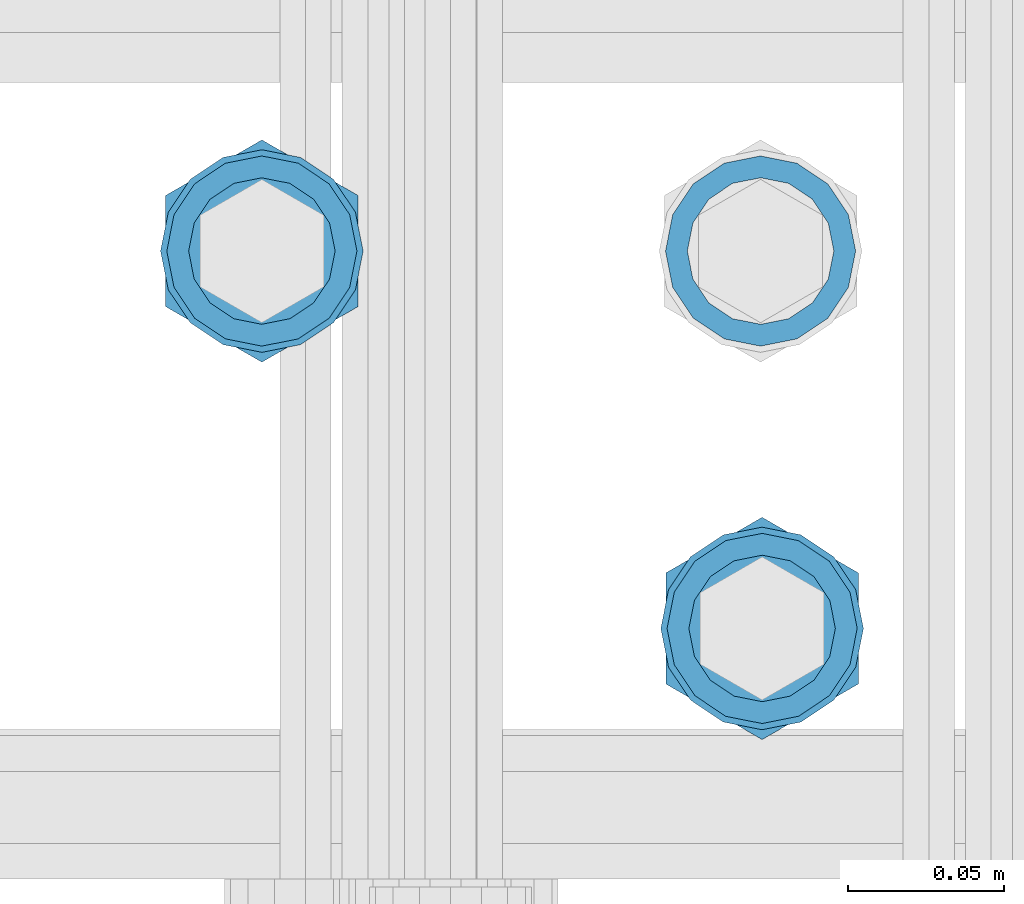
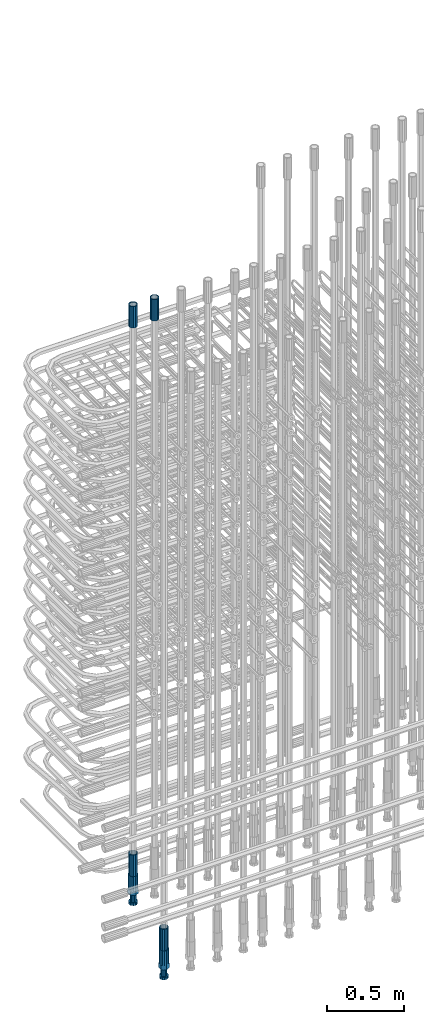
# One storey, part 34 of 177: 6 beams.
"""IFC2X3 building model written with IfcOpenShell, lengths in millimetres."""

from ifc_helpers import new_model, si_unit, frame, origin_with_axes, place, context, subcontext, project, spatial, faceted_brep, material, type_object, element, save


model = new_model("IFC2X3")

# Units and contexts
model_context_1 = context("Model", 3, precision=1e-05, world=origin_with_axes())
model_context_2 = context("Model", 3, precision=1e-05, world=origin_with_axes())
body_context = subcontext(model_context_2, "Body", "Model", "MODEL_VIEW")
ifc_project = project(units=[si_unit("LENGTHUNIT", "METRE", prefix="MILLI"), si_unit("AREAUNIT", "SQUARE_METRE"), si_unit("VOLUMEUNIT", "CUBIC_METRE"), si_unit("MASSUNIT", "GRAM", prefix="KILO"), si_unit("TIMEUNIT", "SECOND"), si_unit("PLANEANGLEUNIT", "RADIAN"), si_unit("SOLIDANGLEUNIT", "STERADIAN"), si_unit("THERMODYNAMICTEMPERATUREUNIT", "DEGREE_CELSIUS"), si_unit("LUMINOUSINTENSITYUNIT", "LUMEN")], contexts=[model_context_1])

# Site, building, storey
site_placement = place(None, origin_with_axes())
site = spatial("IfcSite", under=ifc_project, at=site_placement, CompositionType="ELEMENT")
building_placement = place(site_placement, origin_with_axes())
building = spatial("IfcBuilding", under=site, at=building_placement, Name="Undefined", CompositionType="ELEMENT")
storey_placement = place(building_placement, origin_with_axes())
storey = spatial("IfcBuildingStorey", under=building, at=storey_placement, Name="Undefined", CompositionType="ELEMENT", Elevation=0.0)

# Beams
ifc_material = material(Name="STEEL/S275")
beam_type_1 = type_object("IfcBeamType", PredefinedType="NOTDEFINED")
beam_1_placement = place(storey_placement, frame((2030235.50306268, 6205277.49272666, 23229.9858194793), z_axis=(1.0, 0.0, 0.0), x_axis=(0.0, 0.0, 1.0)))
element("IfcBeam", 1, at=beam_1_placement, inside=storey, type_object=beam_type_1, material=ifc_material, Name="AG40N", context=body_context, shape_type="Brep", body=[
    faceted_brep([(0.0, -23.5000000001164, -9.31322574615479e-10), (0.0, -21.7111690140155, 8.99306066054851), (170.0, -21.7111690140155, 8.99306066054851), (170.0, -23.5, 0.0), (0.0, -16.6170093578839, 16.6170093575493), (170.0, -16.6170093578839, 16.6170093575493), (0.0, -8.99306066057943, 21.7111690137535), (170.0, -8.99306066057943, 21.7111690137535), (0.0, 1.16415321826935e-10, 23.5), (170.0, 0.0, 23.5), (0.0, 8.99306066057943, 21.7111690137535), (170.0, 8.99306066057943, 21.7111690137535), (0.0, 16.6170093578839, 16.6170093575493), (170.0, 16.6170093578839, 16.6170093575493), (0.0, 21.7111690140155, 8.99306066054851), (170.0, 21.7111690140155, 8.99306066054851), (0.0, 23.5000000001164, -9.31322574615479e-10), (170.0, 23.5, 0.0), (0.0, 21.7111690140155, -8.99306066054851), (170.0, 21.7111690140155, -8.99306066054851), (0.0, 16.6170093578839, -16.6170093575493), (170.0, 16.6170093578839, -16.6170093575493), (0.0, 8.99306066057943, -21.7111690137535), (170.0, 8.99306066057943, -21.7111690137535), (0.0, 1.16415321826935e-10, -23.5000000009313), (170.0, 0.0, -23.5), (0.0, -8.99306066057943, -21.7111690137535), (170.0, -8.99306066057943, -21.7111690137535), (0.0, -16.6170093578839, -16.6170093575493), (170.0, -16.6170093578839, -16.6170093575493), (0.0, -21.7111690140155, -8.99306066054851), (170.0, -21.7111690140155, -8.99306066054851), (0.0, -30.5, 0.0), (0.0, -28.1783257415937, -11.6718446873128), (170.0, -28.1783257415937, -11.6718446873128), (170.0, -30.5, 0.0), (0.0, -21.5667568261888, -21.5667568258941), (170.0, -21.5667568261888, -21.5667568258941), (0.0, -11.6718446871346, -28.1783257415518), (170.0, -11.6718446871346, -28.1783257415518), (0.0, 0.0, -30.5), (170.0, 0.0, -30.5), (0.0, 11.6718446871346, -28.1783257415518), (170.0, 11.6718446871346, -28.1783257415518), (0.0, 21.5667568261888, -21.5667568258941), (170.0, 21.5667568261888, -21.5667568258941), (0.0, 28.1783257415937, -11.6718446873128), (170.0, 28.1783257415937, -11.6718446873128), (0.0, 30.5, 0.0), (170.0, 30.5, 0.0), (0.0, 28.1783257415937, 11.6718446873128), (170.0, 28.1783257415937, 11.6718446873128), (0.0, 21.5667568261888, 21.5667568258941), (170.0, 21.5667568261888, 21.5667568258941), (0.0, 11.6718446871346, 28.1783257415518), (170.0, 11.6718446871346, 28.1783257415518), (0.0, 0.0, 30.5), (170.0, 0.0, 30.5), (0.0, -11.6718446871346, 28.1783257415518), (170.0, -11.6718446871346, 28.1783257415518), (0.0, -21.5667568261888, 21.5667568258941), (170.0, -21.5667568261888, 21.5667568258941), (0.0, -28.1783257415937, 11.6718446873128), (170.0, -28.1783257415937, 11.6718446873128)], [[[0, 1, 2, 3]], [[1, 4, 5, 2]], [[4, 6, 7, 5]], [[6, 8, 9, 7]], [[8, 10, 11, 9]], [[10, 12, 13, 11]], [[12, 14, 15, 13]], [[14, 16, 17, 15]], [[16, 18, 19, 17]], [[18, 20, 21, 19]], [[20, 22, 23, 21]], [[22, 24, 25, 23]], [[24, 26, 27, 25]], [[26, 28, 29, 27]], [[28, 30, 31, 29]], [[30, 0, 3, 31]], [[32, 33, 34, 35]], [[33, 36, 37, 34]], [[36, 38, 39, 37]], [[38, 40, 41, 39]], [[40, 42, 43, 41]], [[42, 44, 45, 43]], [[44, 46, 47, 45]], [[46, 48, 49, 47]], [[48, 50, 51, 49]], [[50, 52, 53, 51]], [[52, 54, 55, 53]], [[54, 56, 57, 55]], [[56, 58, 59, 57]], [[58, 60, 61, 59]], [[60, 62, 63, 61]], [[62, 32, 35, 63]], [[37, 39, 41, 43, 45, 47, 49, 51, 53, 55, 57, 59, 61, 63, 35, 34], [5, 7, 9, 11, 13, 15, 17, 19, 21, 23, 25, 27, 29, 31, 3, 2]], [[62, 60, 58, 56, 54, 52, 50, 48, 46, 44, 42, 40, 38, 36, 33, 32], [30, 28, 26, 24, 22, 20, 18, 16, 14, 12, 10, 8, 6, 4, 1, 0]]]),
])
beam_2_placement = place(storey_placement, frame((2030075.5030627, 6205277.49272665, 19060.9668004261), z_axis=(-1.0, 0.0, 0.0), x_axis=(0.0, 0.0, -1.0)))
element("IfcBeam", 2, at=beam_2_placement, inside=storey, type_object=beam_type_1, material=ifc_material, Name="AG40N", context=body_context, shape_type="Brep", body=[
    faceted_brep([(0.0, -23.5000000001164, -9.31322574615479e-10), (0.0, -21.7111690140155, 8.99306066054851), (170.0, -21.7111690140155, 8.99306066054851), (170.0, -23.5, 0.0), (0.0, -16.6170093578839, 16.6170093575493), (170.0, -16.6170093578839, 16.6170093575493), (0.0, -8.99306066057943, 21.7111690137535), (170.0, -8.99306066057943, 21.7111690137535), (0.0, 1.16415321826935e-10, 23.5), (170.0, 0.0, 23.5), (0.0, 8.99306066057943, 21.7111690137535), (170.0, 8.99306066057943, 21.7111690137535), (0.0, 16.6170093578839, 16.6170093575493), (170.0, 16.6170093578839, 16.6170093575493), (0.0, 21.7111690140155, 8.99306066054851), (170.0, 21.7111690140155, 8.99306066054851), (0.0, 23.5000000001164, -9.31322574615479e-10), (170.0, 23.5, 0.0), (0.0, 21.7111690140155, -8.99306066054851), (170.0, 21.7111690140155, -8.99306066054851), (0.0, 16.6170093578839, -16.6170093575493), (170.0, 16.6170093578839, -16.6170093575493), (0.0, 8.99306066057943, -21.7111690137535), (170.0, 8.99306066057943, -21.7111690137535), (0.0, 1.16415321826935e-10, -23.5000000009313), (170.0, 0.0, -23.5), (0.0, -8.99306066057943, -21.7111690137535), (170.0, -8.99306066057943, -21.7111690137535), (0.0, -16.6170093578839, -16.6170093575493), (170.0, -16.6170093578839, -16.6170093575493), (0.0, -21.7111690140155, -8.99306066054851), (170.0, -21.7111690140155, -8.99306066054851), (0.0, -30.5, 0.0), (0.0, -28.1783257415937, -11.6718446873128), (170.0, -28.1783257415937, -11.6718446873128), (170.0, -30.5, 0.0), (0.0, -21.5667568261888, -21.5667568258941), (170.0, -21.5667568261888, -21.5667568258941), (0.0, -11.6718446871346, -28.1783257415518), (170.0, -11.6718446871346, -28.1783257415518), (0.0, 0.0, -30.5), (170.0, 0.0, -30.5), (0.0, 11.6718446871346, -28.1783257415518), (170.0, 11.6718446871346, -28.1783257415518), (0.0, 21.5667568261888, -21.5667568258941), (170.0, 21.5667568261888, -21.5667568258941), (0.0, 28.1783257415937, -11.6718446873128), (170.0, 28.1783257415937, -11.6718446873128), (0.0, 30.5, 0.0), (170.0, 30.5, 0.0), (0.0, 28.1783257415937, 11.6718446873128), (170.0, 28.1783257415937, 11.6718446873128), (0.0, 21.5667568261888, 21.5667568258941), (170.0, 21.5667568261888, 21.5667568258941), (0.0, 11.6718446871346, 28.1783257415518), (170.0, 11.6718446871346, 28.1783257415518), (0.0, 0.0, 30.5), (170.0, 0.0, 30.5), (0.0, -11.6718446871346, 28.1783257415518), (170.0, -11.6718446871346, 28.1783257415518), (0.0, -21.5667568261888, 21.5667568258941), (170.0, -21.5667568261888, 21.5667568258941), (0.0, -28.1783257415937, 11.6718446873128), (170.0, -28.1783257415937, 11.6718446873128)], [[[0, 1, 2, 3]], [[1, 4, 5, 2]], [[4, 6, 7, 5]], [[6, 8, 9, 7]], [[8, 10, 11, 9]], [[10, 12, 13, 11]], [[12, 14, 15, 13]], [[14, 16, 17, 15]], [[16, 18, 19, 17]], [[18, 20, 21, 19]], [[20, 22, 23, 21]], [[22, 24, 25, 23]], [[24, 26, 27, 25]], [[26, 28, 29, 27]], [[28, 30, 31, 29]], [[30, 0, 3, 31]], [[32, 33, 34, 35]], [[33, 36, 37, 34]], [[36, 38, 39, 37]], [[38, 40, 41, 39]], [[40, 42, 43, 41]], [[42, 44, 45, 43]], [[44, 46, 47, 45]], [[46, 48, 49, 47]], [[48, 50, 51, 49]], [[50, 52, 53, 51]], [[52, 54, 55, 53]], [[54, 56, 57, 55]], [[56, 58, 59, 57]], [[58, 60, 61, 59]], [[60, 62, 63, 61]], [[62, 32, 35, 63]], [[37, 39, 41, 43, 45, 47, 49, 51, 53, 55, 57, 59, 61, 63, 35, 34], [5, 7, 9, 11, 13, 15, 17, 19, 21, 23, 25, 27, 29, 31, 3, 2]], [[62, 60, 58, 56, 54, 52, 50, 48, 46, 44, 42, 40, 38, 36, 33, 32], [30, 28, 26, 24, 22, 20, 18, 16, 14, 12, 10, 8, 6, 4, 1, 0]]]),
])
beam_3_placement = place(storey_placement, frame((2030075.50306268, 6205277.49272666, 23229.9858194793), z_axis=(1.0, 0.0, 0.0), x_axis=(0.0, 0.0, 1.0)))
element("IfcBeam", 3, at=beam_3_placement, inside=storey, type_object=beam_type_1, material=ifc_material, Name="AG40N", context=body_context, shape_type="Brep", body=[
    faceted_brep([(0.0, -23.5000000001164, -9.31322574615479e-10), (0.0, -21.7111690140155, 8.99306066054851), (170.0, -21.7111690140155, 8.99306066054851), (170.0, -23.5, 0.0), (0.0, -16.6170093578839, 16.6170093575493), (170.0, -16.6170093578839, 16.6170093575493), (0.0, -8.99306066057943, 21.7111690137535), (170.0, -8.99306066057943, 21.7111690137535), (0.0, 1.16415321826935e-10, 23.5), (170.0, 0.0, 23.5), (0.0, 8.99306066057943, 21.7111690137535), (170.0, 8.99306066057943, 21.7111690137535), (0.0, 16.6170093578839, 16.6170093575493), (170.0, 16.6170093578839, 16.6170093575493), (0.0, 21.7111690140155, 8.99306066054851), (170.0, 21.7111690140155, 8.99306066054851), (0.0, 23.5000000001164, -9.31322574615479e-10), (170.0, 23.5, 0.0), (0.0, 21.7111690140155, -8.99306066054851), (170.0, 21.7111690140155, -8.99306066054851), (0.0, 16.6170093578839, -16.6170093575493), (170.0, 16.6170093578839, -16.6170093575493), (0.0, 8.99306066057943, -21.7111690137535), (170.0, 8.99306066057943, -21.7111690137535), (0.0, 1.16415321826935e-10, -23.5000000009313), (170.0, 0.0, -23.5), (0.0, -8.99306066057943, -21.7111690137535), (170.0, -8.99306066057943, -21.7111690137535), (0.0, -16.6170093578839, -16.6170093575493), (170.0, -16.6170093578839, -16.6170093575493), (0.0, -21.7111690140155, -8.99306066054851), (170.0, -21.7111690140155, -8.99306066054851), (0.0, -30.5, 0.0), (0.0, -28.1783257415937, -11.6718446873128), (170.0, -28.1783257415937, -11.6718446873128), (170.0, -30.5, 0.0), (0.0, -21.5667568261888, -21.5667568258941), (170.0, -21.5667568261888, -21.5667568258941), (0.0, -11.6718446871346, -28.1783257415518), (170.0, -11.6718446871346, -28.1783257415518), (0.0, 0.0, -30.5), (170.0, 0.0, -30.5), (0.0, 11.6718446871346, -28.1783257415518), (170.0, 11.6718446871346, -28.1783257415518), (0.0, 21.5667568261888, -21.5667568258941), (170.0, 21.5667568261888, -21.5667568258941), (0.0, 28.1783257415937, -11.6718446873128), (170.0, 28.1783257415937, -11.6718446873128), (0.0, 30.5, 0.0), (170.0, 30.5, 0.0), (0.0, 28.1783257415937, 11.6718446873128), (170.0, 28.1783257415937, 11.6718446873128), (0.0, 21.5667568261888, 21.5667568258941), (170.0, 21.5667568261888, 21.5667568258941), (0.0, 11.6718446871346, 28.1783257415518), (170.0, 11.6718446871346, 28.1783257415518), (0.0, 0.0, 30.5), (170.0, 0.0, 30.5), (0.0, -11.6718446871346, 28.1783257415518), (170.0, -11.6718446871346, 28.1783257415518), (0.0, -21.5667568261888, 21.5667568258941), (170.0, -21.5667568261888, 21.5667568258941), (0.0, -28.1783257415937, 11.6718446873128), (170.0, -28.1783257415937, 11.6718446873128)], [[[0, 1, 2, 3]], [[1, 4, 5, 2]], [[4, 6, 7, 5]], [[6, 8, 9, 7]], [[8, 10, 11, 9]], [[10, 12, 13, 11]], [[12, 14, 15, 13]], [[14, 16, 17, 15]], [[16, 18, 19, 17]], [[18, 20, 21, 19]], [[20, 22, 23, 21]], [[22, 24, 25, 23]], [[24, 26, 27, 25]], [[26, 28, 29, 27]], [[28, 30, 31, 29]], [[30, 0, 3, 31]], [[32, 33, 34, 35]], [[33, 36, 37, 34]], [[36, 38, 39, 37]], [[38, 40, 41, 39]], [[40, 42, 43, 41]], [[42, 44, 45, 43]], [[44, 46, 47, 45]], [[46, 48, 49, 47]], [[48, 50, 51, 49]], [[50, 52, 53, 51]], [[52, 54, 55, 53]], [[54, 56, 57, 55]], [[56, 58, 59, 57]], [[58, 60, 61, 59]], [[60, 62, 63, 61]], [[62, 32, 35, 63]], [[37, 39, 41, 43, 45, 47, 49, 51, 53, 55, 57, 59, 61, 63, 35, 34], [5, 7, 9, 11, 13, 15, 17, 19, 21, 23, 25, 27, 29, 31, 3, 2]], [[62, 60, 58, 56, 54, 52, 50, 48, 46, 44, 42, 40, 38, 36, 33, 32], [30, 28, 26, 24, 22, 20, 18, 16, 14, 12, 10, 8, 6, 4, 1, 0]]]),
])
beam_4_placement = place(storey_placement, frame((2030236.00256268, 6205156.4084753, 18490.9668004282), z_axis=(-1.0, 0.0, 0.0), x_axis=(0.0, 0.0, -1.0)))
element("IfcBeam", 4, at=beam_4_placement, inside=storey, type_object=beam_type_1, material=ifc_material, Name="AG40N", context=body_context, shape_type="Brep", body=[
    faceted_brep([(0.0, -23.5000000001164, -9.31322574615479e-10), (0.0, -21.7111690140155, 8.99306066054851), (170.0, -21.7111690140155, 8.99306066054851), (170.0, -23.5, 0.0), (0.0, -16.6170093578839, 16.6170093575493), (170.0, -16.6170093578839, 16.6170093575493), (0.0, -8.99306066057943, 21.7111690137535), (170.0, -8.99306066057943, 21.7111690137535), (0.0, 1.16415321826935e-10, 23.5), (170.0, 0.0, 23.5), (0.0, 8.99306066057943, 21.7111690137535), (170.0, 8.99306066057943, 21.7111690137535), (0.0, 16.6170093578839, 16.6170093575493), (170.0, 16.6170093578839, 16.6170093575493), (0.0, 21.7111690140155, 8.99306066054851), (170.0, 21.7111690140155, 8.99306066054851), (0.0, 23.5000000001164, -9.31322574615479e-10), (170.0, 23.5, 0.0), (0.0, 21.7111690140155, -8.99306066054851), (170.0, 21.7111690140155, -8.99306066054851), (0.0, 16.6170093578839, -16.6170093575493), (170.0, 16.6170093578839, -16.6170093575493), (0.0, 8.99306066057943, -21.7111690137535), (170.0, 8.99306066057943, -21.7111690137535), (0.0, 1.16415321826935e-10, -23.5000000009313), (170.0, 0.0, -23.5), (0.0, -8.99306066057943, -21.7111690137535), (170.0, -8.99306066057943, -21.7111690137535), (0.0, -16.6170093578839, -16.6170093575493), (170.0, -16.6170093578839, -16.6170093575493), (0.0, -21.7111690140155, -8.99306066054851), (170.0, -21.7111690140155, -8.99306066054851), (0.0, -30.5, 0.0), (0.0, -28.1783257415937, -11.6718446873128), (170.0, -28.1783257415937, -11.6718446873128), (170.0, -30.5, 0.0), (0.0, -21.5667568261888, -21.5667568258941), (170.0, -21.5667568261888, -21.5667568258941), (0.0, -11.6718446871346, -28.1783257415518), (170.0, -11.6718446871346, -28.1783257415518), (0.0, 0.0, -30.5), (170.0, 0.0, -30.5), (0.0, 11.6718446871346, -28.1783257415518), (170.0, 11.6718446871346, -28.1783257415518), (0.0, 21.5667568261888, -21.5667568258941), (170.0, 21.5667568261888, -21.5667568258941), (0.0, 28.1783257415937, -11.6718446873128), (170.0, 28.1783257415937, -11.6718446873128), (0.0, 30.5, 0.0), (170.0, 30.5, 0.0), (0.0, 28.1783257415937, 11.6718446873128), (170.0, 28.1783257415937, 11.6718446873128), (0.0, 21.5667568261888, 21.5667568258941), (170.0, 21.5667568261888, 21.5667568258941), (0.0, 11.6718446871346, 28.1783257415518), (170.0, 11.6718446871346, 28.1783257415518), (0.0, 0.0, 30.5), (170.0, 0.0, 30.5), (0.0, -11.6718446871346, 28.1783257415518), (170.0, -11.6718446871346, 28.1783257415518), (0.0, -21.5667568261888, 21.5667568258941), (170.0, -21.5667568261888, 21.5667568258941), (0.0, -28.1783257415937, 11.6718446873128), (170.0, -28.1783257415937, 11.6718446873128)], [[[0, 1, 2, 3]], [[1, 4, 5, 2]], [[4, 6, 7, 5]], [[6, 8, 9, 7]], [[8, 10, 11, 9]], [[10, 12, 13, 11]], [[12, 14, 15, 13]], [[14, 16, 17, 15]], [[16, 18, 19, 17]], [[18, 20, 21, 19]], [[20, 22, 23, 21]], [[22, 24, 25, 23]], [[24, 26, 27, 25]], [[26, 28, 29, 27]], [[28, 30, 31, 29]], [[30, 0, 3, 31]], [[32, 33, 34, 35]], [[33, 36, 37, 34]], [[36, 38, 39, 37]], [[38, 40, 41, 39]], [[40, 42, 43, 41]], [[42, 44, 45, 43]], [[44, 46, 47, 45]], [[46, 48, 49, 47]], [[48, 50, 51, 49]], [[50, 52, 53, 51]], [[52, 54, 55, 53]], [[54, 56, 57, 55]], [[56, 58, 59, 57]], [[58, 60, 61, 59]], [[60, 62, 63, 61]], [[62, 32, 35, 63]], [[37, 39, 41, 43, 45, 47, 49, 51, 53, 55, 57, 59, 61, 63, 35, 34], [5, 7, 9, 11, 13, 15, 17, 19, 21, 23, 25, 27, 29, 31, 3, 2]], [[62, 60, 58, 56, 54, 52, 50, 48, 46, 44, 42, 40, 38, 36, 33, 32], [30, 28, 26, 24, 22, 20, 18, 16, 14, 12, 10, 8, 6, 4, 1, 0]]]),
])
beam_type_2 = type_object("IfcBeamType", Name="ROD65", PredefinedType="NOTDEFINED")
beam_5_placement = place(storey_placement, frame((2030075.50306269, 6205277.49272665, 18890.9668004261), z_axis=(-1.0, 0.0, 0.0), x_axis=(0.0, 0.0, -1.0)))
element("IfcBeam", 5, at=beam_5_placement, inside=storey, type_object=beam_type_2, material=ifc_material, Name="AGB40", ObjectType="ROD65", context=body_context, shape_type="Brep", body=[
    faceted_brep([(117.0, 8.17543110251427, 30.873805644922), (117.0, 17.8250000001863, 30.873805644922), (117.0, 22.0056958701462, 23.6326279877685), (117.0, 12.4372115517035, 30.0260848065373), (117.0, -17.8250000001863, 30.873805644922), (150.200000000186, -17.8250000001863, 30.873805644922), (150.200000000186, 17.8250000001863, 30.873805644922), (117.0, -8.17543110251427, 30.873805644922), (117.0, -12.4372115517035, 30.0260848065373), (117.0, -22.0056958701462, 23.6326279877685), (117.0, -35.6500000003725, 0.0), (150.200000000186, -35.6500000003725, 0.0), (117.0, -30.8443150008097, 8.32369058486074), (117.0, -32.5, 0.0), (117.0, -30.8443150008097, -8.32369058462791), (117.0, -17.8250000001863, -30.873805644922), (150.200000000186, -17.8250000001863, -30.873805644922), (117.0, -22.0056958701462, -23.6326279877685), (117.0, -12.4372115517035, -30.0260848065373), (117.0, -8.17543110251427, -30.873805644922), (117.0, 17.8250000001863, -30.873805644922), (150.200000000186, 17.8250000001863, -30.873805644922), (117.0, 8.17543110251427, -30.873805644922), (117.0, 22.0056958701462, -23.6326279877685), (117.0, 12.4372115517035, -30.0260848065373), (117.0, 35.6500000003725, 0.0), (150.200000000186, 35.6500000003725, 0.0), (117.0, 30.8443150008097, -8.32369058486074), (117.0, 30.8443150008097, 8.32369058462791), (117.0, 32.5, 0.0), (0.0, -22.9809703892097, 22.9809703885621), (0.0, -30.0260848058388, 12.4372115518636), (117.0, -30.0260848067701, 12.4372115519363), (117.0, -22.9809703882784, 22.9809703885112), (-2.3283064365387e-10, 22.9809703892097, -22.9809703885639), (-4.65661287307739e-10, 30.0260848077014, -12.4372115518672), (117.0, 30.0260848067701, -12.4372115519363), (117.0, 22.9809703882784, -22.9809703885112), (-2.3283064365387e-10, -30.0260848067701, -12.4372115518672), (-2.3283064365387e-10, -22.9809703892097, -22.9809703885621), (117.0, -22.9809703882784, -22.9809703885112), (117.0, -30.0260848067701, -12.4372115519363), (-2.3283064365387e-10, -12.4372115507722, 30.0260848066137), (-2.3283064365387e-10, 9.31322574615479e-10, 32.4999999999982), (-2.3283064365387e-10, 12.4372115526348, 30.0260848066137), (0.0, 22.9809703892097, 22.9809703885621), (-2.3283064365387e-10, 30.0260848077014, 12.4372115518636), (-2.3283064365387e-10, 32.5, 0.0), (-2.3283064365387e-10, 12.4372115526348, -30.0260848066173), (-2.3283064365387e-10, 9.31322574615479e-10, -32.5), (-2.3283064365387e-10, -12.4372115517035, -30.0260848066173), (-4.65661287307739e-10, -32.4999999990687, -1.81898940354586e-12), (117.0, 22.9809703882784, 22.9809703885112), (117.0, 30.0260848067701, 12.4372115519363), (117.0, 0.0, -32.5), (117.0, 0.0, 32.5), (150.200000000186, 10.5, -18.1865334794857), (150.200000000186, 0.0, -21.0), (150.200000000186, -10.5, -18.1865334794857), (150.200000000186, -18.18653347902, -10.5), (150.200000000186, -21.0, 0.0), (150.200000000186, -18.18653347902, 10.5), (150.200000000186, -10.5, 18.1865334794857), (150.200000000186, 0.0, 21.0), (150.200000000186, 10.5, 18.1865334794857), (150.200000000186, 18.18653347902, 10.5), (150.200000000186, 21.0, 0.0), (150.200000000186, 18.18653347902, -10.5), (210.980000000447, -10.5, -18.1865334794857), (210.980000000447, 0.0, -21.0), (210.980000000447, -18.18653347902, -10.5), (210.980000000447, -21.0, 0.0), (210.980000000447, -18.18653347902, 10.5), (210.980000000447, -10.5, 18.1865334794857), (210.980000000447, 0.0, 21.0), (210.980000000447, 10.5, 18.1865334794857), (210.980000000447, 18.18653347902, 10.5), (210.980000000447, 21.0, 0.0), (210.980000000447, 18.18653347902, -10.5), (210.980000000447, 10.5, -18.1865334794857), (211.001368442696, -27.7269937992096, -11.491116326768), (211.003082550167, -21.2238094303757, -21.223815418547), (231.002518367059, -21.2131944671273, -21.2132004550658), (231.000804259587, -27.7163788359612, -11.4805013632867), (211.001368440451, -11.4911085031927, -27.7269970395137), (231.000804257343, -11.4804935399443, -27.7163820760325), (210.996487071217, -0.0106065049767494, -30.0106107392348), (230.995922888109, 8.45827162265778e-06, -29.9999957757536), (210.989181586672, 11.46989420522, -27.7269970329944), (230.988617403564, 11.4805091684684, -27.7163820695132), (210.980564180623, 21.2025914648548, -21.2238154064398), (230.979999997515, 21.2132064281031, -21.2132004429586), (210.971946775022, 27.7057703435421, -11.4911163107026), (230.971382591913, 27.7163853067905, -11.4805013472214), (210.96464129175, 29.9893808094785, -0.0106149562634528), (230.964077108642, 29.9999957727268, 7.21774995326996e-09), (210.959759924415, 27.7057638689876, 11.4698863970116), (230.959195741307, 27.7163788322359, 11.4805013604928), (210.958045816944, 21.2025795001537, 21.2025854887906), (230.957481633835, 21.213194463402, 21.2132004522718), (210.95975992666, 11.4698785729706, 27.7057671097573), (230.959195743551, 11.480493536219, 27.7163820732385), (210.964641295894, -0.010623425245285, 29.9893808094785), (230.964077112785, -8.46199691295624e-06, 29.9999957729597), (210.971946780439, -11.4911241354421, 27.705767103238), (230.97138259733, -11.4805091721937, 27.7163820667192), (210.980564186488, -21.2238213950768, 21.2025854766835), (230.980000003379, -21.2132064318284, 21.2132004401647), (210.989181592089, -27.7270002737641, 11.4698863809463), (230.988617408981, -27.7163853105158, 11.4805013444275), (210.996487075361, -30.0106107397005, -0.0106149734929204), (230.995922892253, -29.9999957764521, -1.00117176771164e-08)], [[[0, 1, 2, 3]], [[4, 5, 6, 1, 0, 7]], [[4, 7, 8, 9]], [[10, 11, 5, 4, 9, 12]], [[10, 12, 13, 14]], [[15, 16, 11, 10, 14, 17]], [[15, 17, 18, 19]], [[20, 21, 16, 15, 19, 22]], [[23, 20, 22, 24]], [[25, 26, 21, 20, 23, 27]], [[28, 25, 27, 29]], [[30, 31, 32, 33]], [[34, 35, 36, 37]], [[38, 39, 40, 41]], [[31, 30, 42, 43, 44, 45, 46, 47, 35, 34, 48, 49, 50, 39, 38, 51]], [[46, 45, 52, 53]], [[29, 47, 46, 53, 28]], [[27, 36, 35, 47, 29]], [[23, 37, 36, 27]], [[24, 48, 34, 37, 23]], [[22, 54, 49, 48, 24]], [[19, 54, 22]], [[18, 50, 49, 54, 19]], [[17, 40, 39, 50, 18]], [[14, 41, 40, 17]], [[13, 51, 38, 41, 14]], [[12, 32, 31, 51, 13]], [[9, 33, 32, 12]], [[8, 42, 30, 33, 9]], [[7, 55, 43, 42, 8]], [[0, 55, 7]], [[3, 44, 43, 55, 0]], [[2, 52, 45, 44, 3]], [[28, 53, 52, 2]], [[1, 6, 26, 25, 28, 2]], [[5, 11, 16, 21, 26, 6], [56, 57, 58, 59, 60, 61, 62, 63, 64, 65, 66, 67]], [[68, 58, 57, 69]], [[70, 59, 58, 68]], [[71, 60, 59, 70]], [[72, 61, 60, 71]], [[73, 62, 61, 72]], [[74, 63, 62, 73]], [[75, 64, 63, 74]], [[76, 65, 64, 75]], [[77, 66, 65, 76]], [[78, 67, 66, 77]], [[79, 56, 67, 78]], [[69, 57, 56, 79]], [[80, 81, 82, 83]], [[81, 84, 85, 82]], [[84, 86, 87, 85]], [[86, 88, 89, 87]], [[88, 90, 91, 89]], [[90, 92, 93, 91]], [[92, 94, 95, 93]], [[94, 96, 97, 95]], [[96, 98, 99, 97]], [[98, 100, 101, 99]], [[100, 102, 103, 101]], [[102, 104, 105, 103]], [[104, 106, 107, 105]], [[106, 108, 109, 107]], [[108, 110, 111, 109]], [[82, 85, 87, 89, 91, 93, 95, 97, 99, 101, 103, 105, 107, 109, 111, 83]], [[110, 80, 83, 111]], [[108, 106, 104, 102, 100, 98, 96, 94, 92, 90, 88, 86, 84, 81, 80, 110], [78, 77, 76, 75, 74, 73, 72, 71, 70, 68, 69, 79]]]),
])
beam_6_placement = place(storey_placement, frame((2030236.00256267, 6205156.4084753, 18320.9668004282), z_axis=(-1.0, 0.0, 0.0), x_axis=(0.0, 0.0, -1.0)))
element("IfcBeam", 6, at=beam_6_placement, inside=storey, type_object=beam_type_2, material=ifc_material, Name="AGB40", ObjectType="ROD65", context=body_context, shape_type="Brep", body=[
    faceted_brep([(117.0, 8.17543110251427, 30.873805644922), (117.0, 17.8250000001863, 30.873805644922), (117.0, 22.0056958701462, 23.6326279877685), (117.0, 12.4372115517035, 30.0260848065373), (117.0, -17.8250000001863, 30.873805644922), (150.200000000186, -17.8250000001863, 30.873805644922), (150.200000000186, 17.8250000001863, 30.873805644922), (117.0, -8.17543110251427, 30.873805644922), (117.0, -12.4372115517035, 30.0260848065373), (117.0, -22.0056958701462, 23.6326279877685), (117.0, -35.6500000003725, 0.0), (150.200000000186, -35.6500000003725, 0.0), (117.0, -30.8443150008097, 8.32369058486074), (117.0, -32.5, 0.0), (117.0, -30.8443150008097, -8.32369058462791), (117.0, -17.8250000001863, -30.873805644922), (150.200000000186, -17.8250000001863, -30.873805644922), (117.0, -22.0056958701462, -23.6326279877685), (117.0, -12.4372115517035, -30.0260848065373), (117.0, -8.17543110251427, -30.873805644922), (117.0, 17.8250000001863, -30.873805644922), (150.200000000186, 17.8250000001863, -30.873805644922), (117.0, 8.17543110251427, -30.873805644922), (117.0, 22.0056958701462, -23.6326279877685), (117.0, 12.4372115517035, -30.0260848065373), (117.0, 35.6500000003725, 0.0), (150.200000000186, 35.6500000003725, 0.0), (117.0, 30.8443150008097, -8.32369058486074), (117.0, 30.8443150008097, 8.32369058462791), (117.0, 32.5, 0.0), (0.0, -22.9809703892097, 22.9809703885621), (0.0, -30.0260848058388, 12.4372115518636), (117.0, -30.0260848067701, 12.4372115519363), (117.0, -22.9809703882784, 22.9809703885112), (-2.3283064365387e-10, 22.9809703892097, -22.9809703885639), (-4.65661287307739e-10, 30.0260848077014, -12.4372115518672), (117.0, 30.0260848067701, -12.4372115519363), (117.0, 22.9809703882784, -22.9809703885112), (-2.3283064365387e-10, -30.0260848067701, -12.4372115518672), (-2.3283064365387e-10, -22.9809703892097, -22.9809703885621), (117.0, -22.9809703882784, -22.9809703885112), (117.0, -30.0260848067701, -12.4372115519363), (-2.3283064365387e-10, -12.4372115507722, 30.0260848066137), (-2.3283064365387e-10, 9.31322574615479e-10, 32.4999999999982), (-2.3283064365387e-10, 12.4372115526348, 30.0260848066137), (0.0, 22.9809703892097, 22.9809703885621), (-2.3283064365387e-10, 30.0260848077014, 12.4372115518636), (-2.3283064365387e-10, 32.5, 0.0), (-2.3283064365387e-10, 12.4372115526348, -30.0260848066173), (-2.3283064365387e-10, 9.31322574615479e-10, -32.5), (-2.3283064365387e-10, -12.4372115517035, -30.0260848066173), (-4.65661287307739e-10, -32.4999999990687, -1.81898940354586e-12), (117.0, 22.9809703882784, 22.9809703885112), (117.0, 30.0260848067701, 12.4372115519363), (117.0, 0.0, -32.5), (117.0, 0.0, 32.5), (150.200000000186, 10.5, -18.1865334794857), (150.200000000186, 0.0, -21.0), (150.200000000186, -10.5, -18.1865334794857), (150.200000000186, -18.18653347902, -10.5), (150.200000000186, -21.0, 0.0), (150.200000000186, -18.18653347902, 10.5), (150.200000000186, -10.5, 18.1865334794857), (150.200000000186, 0.0, 21.0), (150.200000000186, 10.5, 18.1865334794857), (150.200000000186, 18.18653347902, 10.5), (150.200000000186, 21.0, 0.0), (150.200000000186, 18.18653347902, -10.5), (210.980000000447, -10.5, -18.1865334794857), (210.980000000447, 0.0, -21.0), (210.980000000447, -18.18653347902, -10.5), (210.980000000447, -21.0, 0.0), (210.980000000447, -18.18653347902, 10.5), (210.980000000447, -10.5, 18.1865334794857), (210.980000000447, 0.0, 21.0), (210.980000000447, 10.5, 18.1865334794857), (210.980000000447, 18.18653347902, 10.5), (210.980000000447, 21.0, 0.0), (210.980000000447, 18.18653347902, -10.5), (210.980000000447, 10.5, -18.1865334794857), (211.001368442696, -27.7269937992096, -11.491116326768), (211.003082550167, -21.2238094303757, -21.223815418547), (231.002518367059, -21.2131944671273, -21.2132004550658), (231.000804259587, -27.7163788359612, -11.4805013632867), (211.001368440451, -11.4911085031927, -27.7269970395137), (231.000804257343, -11.4804935399443, -27.7163820760325), (210.996487071217, -0.0106065049767494, -30.0106107392348), (230.995922888109, 8.45827162265778e-06, -29.9999957757536), (210.989181586672, 11.46989420522, -27.7269970329944), (230.988617403564, 11.4805091684684, -27.7163820695132), (210.980564180623, 21.2025914648548, -21.2238154064398), (230.979999997515, 21.2132064281031, -21.2132004429586), (210.971946775022, 27.7057703435421, -11.4911163107026), (230.971382591913, 27.7163853067905, -11.4805013472214), (210.96464129175, 29.9893808094785, -0.0106149562634528), (230.964077108642, 29.9999957727268, 7.21774995326996e-09), (210.959759924415, 27.7057638689876, 11.4698863970116), (230.959195741307, 27.7163788322359, 11.4805013604928), (210.958045816944, 21.2025795001537, 21.2025854887906), (230.957481633835, 21.213194463402, 21.2132004522718), (210.95975992666, 11.4698785729706, 27.7057671097573), (230.959195743551, 11.480493536219, 27.7163820732385), (210.964641295894, -0.010623425245285, 29.9893808094785), (230.964077112785, -8.46199691295624e-06, 29.9999957729597), (210.971946780439, -11.4911241354421, 27.705767103238), (230.97138259733, -11.4805091721937, 27.7163820667192), (210.980564186488, -21.2238213950768, 21.2025854766835), (230.980000003379, -21.2132064318284, 21.2132004401647), (210.989181592089, -27.7270002737641, 11.4698863809463), (230.988617408981, -27.7163853105158, 11.4805013444275), (210.996487075361, -30.0106107397005, -0.0106149734929204), (230.995922892253, -29.9999957764521, -1.00117176771164e-08)], [[[0, 1, 2, 3]], [[4, 5, 6, 1, 0, 7]], [[4, 7, 8, 9]], [[10, 11, 5, 4, 9, 12]], [[10, 12, 13, 14]], [[15, 16, 11, 10, 14, 17]], [[15, 17, 18, 19]], [[20, 21, 16, 15, 19, 22]], [[23, 20, 22, 24]], [[25, 26, 21, 20, 23, 27]], [[28, 25, 27, 29]], [[30, 31, 32, 33]], [[34, 35, 36, 37]], [[38, 39, 40, 41]], [[31, 30, 42, 43, 44, 45, 46, 47, 35, 34, 48, 49, 50, 39, 38, 51]], [[46, 45, 52, 53]], [[29, 47, 46, 53, 28]], [[27, 36, 35, 47, 29]], [[23, 37, 36, 27]], [[24, 48, 34, 37, 23]], [[22, 54, 49, 48, 24]], [[19, 54, 22]], [[18, 50, 49, 54, 19]], [[17, 40, 39, 50, 18]], [[14, 41, 40, 17]], [[13, 51, 38, 41, 14]], [[12, 32, 31, 51, 13]], [[9, 33, 32, 12]], [[8, 42, 30, 33, 9]], [[7, 55, 43, 42, 8]], [[0, 55, 7]], [[3, 44, 43, 55, 0]], [[2, 52, 45, 44, 3]], [[28, 53, 52, 2]], [[1, 6, 26, 25, 28, 2]], [[5, 11, 16, 21, 26, 6], [56, 57, 58, 59, 60, 61, 62, 63, 64, 65, 66, 67]], [[68, 58, 57, 69]], [[70, 59, 58, 68]], [[71, 60, 59, 70]], [[72, 61, 60, 71]], [[73, 62, 61, 72]], [[74, 63, 62, 73]], [[75, 64, 63, 74]], [[76, 65, 64, 75]], [[77, 66, 65, 76]], [[78, 67, 66, 77]], [[79, 56, 67, 78]], [[69, 57, 56, 79]], [[80, 81, 82, 83]], [[81, 84, 85, 82]], [[84, 86, 87, 85]], [[86, 88, 89, 87]], [[88, 90, 91, 89]], [[90, 92, 93, 91]], [[92, 94, 95, 93]], [[94, 96, 97, 95]], [[96, 98, 99, 97]], [[98, 100, 101, 99]], [[100, 102, 103, 101]], [[102, 104, 105, 103]], [[104, 106, 107, 105]], [[106, 108, 109, 107]], [[108, 110, 111, 109]], [[82, 85, 87, 89, 91, 93, 95, 97, 99, 101, 103, 105, 107, 109, 111, 83]], [[110, 80, 83, 111]], [[108, 106, 104, 102, 100, 98, 96, 94, 92, 90, 88, 86, 84, 81, 80, 110], [78, 77, 76, 75, 74, 73, 72, 71, 70, 68, 69, 79]]]),
])

save(model, "model.ifc")
